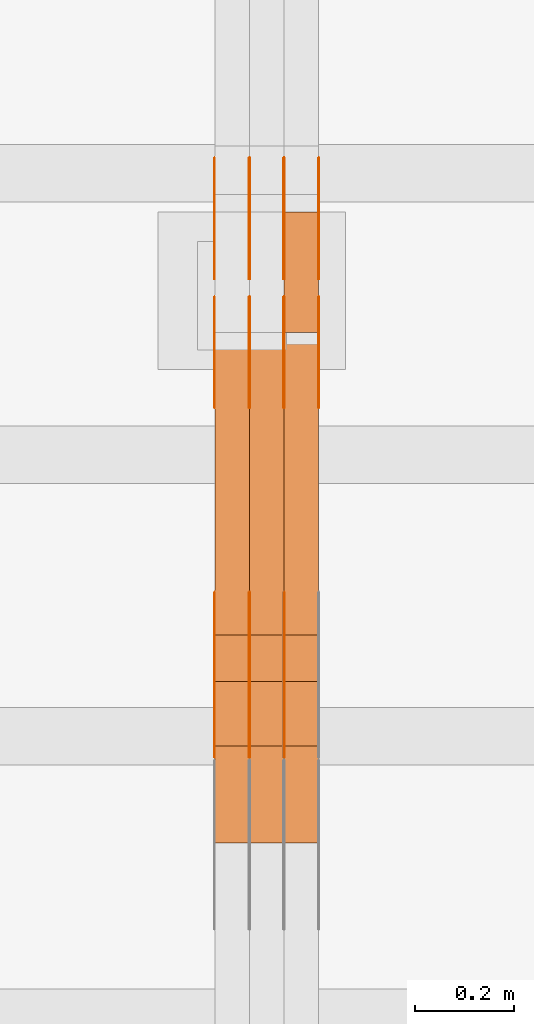
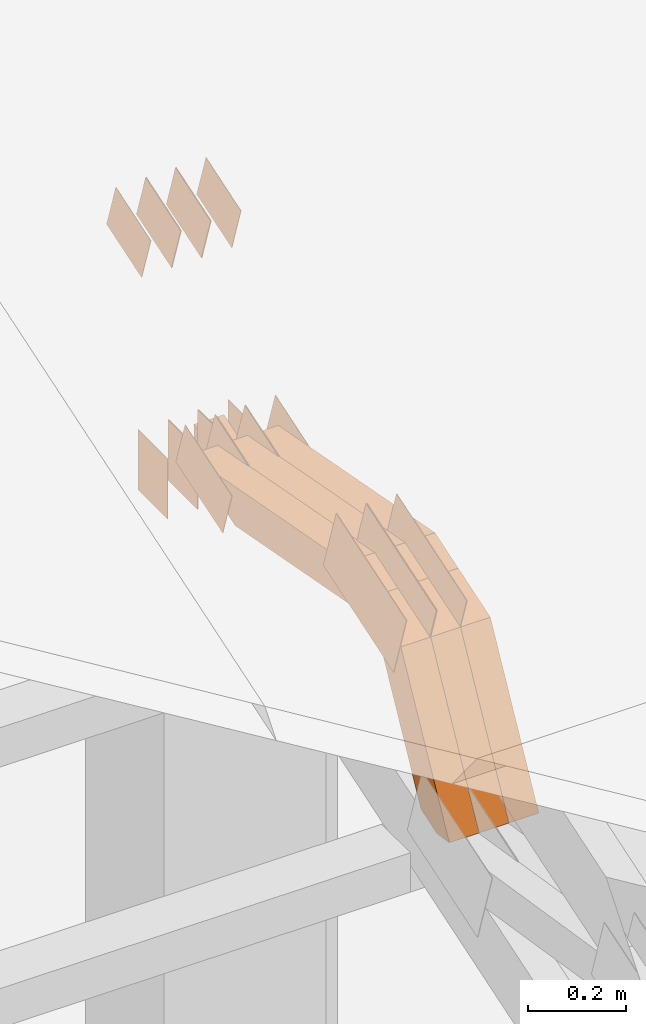
# One storey, part 142 of 385: 29 proxies.
"""IFC2X3 building model written with IfcOpenShell, lengths in millimetres."""

from ifc_helpers import new_model, entity, si_unit, converted_unit, derived_unit, direction, frame, frame_2d, origin, place, context, subcontext, project, spatial, polyline, rectangle, outline, extrude, source, transform, mapped, material, type_object, type_shapes, element, save


model = new_model("IFC2X3")

# Units and contexts
model_context = context("Model", 3, precision=0.01, world=origin(), true_north=direction((6.12303176911189e-17, 1.0)))
body_context = subcontext(model_context, "Body", "Model", "MODEL_VIEW")
ifc_project = project(units=[si_unit("LENGTHUNIT", "METRE", prefix="MILLI"), si_unit("AREAUNIT", "SQUARE_METRE"), si_unit("VOLUMEUNIT", "CUBIC_METRE"), converted_unit("PLANEANGLEUNIT", "DEGREE", entity("IfcRatioMeasure", 0.0174532925199433), si_unit("PLANEANGLEUNIT", "RADIAN"), dimensions=[0, 0, 0, 0, 0, 0, 0]), si_unit("MASSUNIT", "GRAM", prefix="KILO"), derived_unit("MASSDENSITYUNIT", [(si_unit("MASSUNIT", "GRAM", prefix="KILO"), 1), (si_unit("LENGTHUNIT", "METRE"), -3)]), si_unit("TIMEUNIT", "SECOND"), si_unit("FREQUENCYUNIT", "HERTZ"), si_unit("THERMODYNAMICTEMPERATUREUNIT", "DEGREE_CELSIUS"), derived_unit("THERMALTRANSMITTANCEUNIT", [(si_unit("MASSUNIT", "GRAM", prefix="KILO"), 1), (si_unit("THERMODYNAMICTEMPERATUREUNIT", "KELVIN"), -1), (si_unit("TIMEUNIT", "SECOND"), -3)]), derived_unit("VOLUMETRICFLOWRATEUNIT", [(si_unit("LENGTHUNIT", "METRE"), 3), (si_unit("TIMEUNIT", "SECOND"), -1)]), si_unit("ELECTRICCURRENTUNIT", "AMPERE"), si_unit("ELECTRICVOLTAGEUNIT", "VOLT"), si_unit("POWERUNIT", "WATT"), si_unit("FORCEUNIT", "NEWTON", prefix="KILO"), si_unit("ILLUMINANCEUNIT", "LUX"), si_unit("LUMINOUSFLUXUNIT", "LUMEN"), si_unit("LUMINOUSINTENSITYUNIT", "CANDELA"), derived_unit("USERDEFINED", [(si_unit("MASSUNIT", "GRAM", prefix="KILO"), -1), (si_unit("LENGTHUNIT", "METRE"), -2), (si_unit("TIMEUNIT", "SECOND"), 3), (si_unit("LUMINOUSFLUXUNIT", "LUMEN"), 1)]), derived_unit("LINEARVELOCITYUNIT", [(si_unit("LENGTHUNIT", "METRE"), 1), (si_unit("TIMEUNIT", "SECOND"), -1)]), si_unit("PRESSUREUNIT", "PASCAL"), derived_unit("USERDEFINED", [(si_unit("LENGTHUNIT", "METRE"), -2), (si_unit("MASSUNIT", "GRAM", prefix="KILO"), 1), (si_unit("TIMEUNIT", "SECOND"), -2)])], contexts=[model_context])

# Site, building, storey
site_placement = place(None, origin())
site = spatial("IfcSite", under=ifc_project, at=site_placement, CompositionType="ELEMENT")
building_placement = place(site_placement, origin())
building = spatial("IfcBuilding", under=site, at=building_placement, CompositionType="ELEMENT")
storey_placement = place(building_placement, origin())
storey = spatial("IfcBuildingStorey", under=building, at=storey_placement, Name="Default", CompositionType="ELEMENT", Elevation=0.0)

# Proxies
ifc_material_1 = material(Name="IfcSurfaceStyle #241520")
building_element_proxy_type_1 = type_object("IfcBuildingElementProxyType", PredefinedType="NOTDEFINED", material=ifc_material_1)
shared_shape_1 = source(origin(), body_context, "Body", "SweptSolid", [
    extrude(outline(polyline([(-99.9997874178038, -60.0000528641967), (99.9998102700997, -60.0000528641967), (99.9998251396068, 60.0000528641967), (-99.9998479919027, 60.0000528641967), (-99.9997874178038, -60.0000528641967)])), frame((99.9999918898597, 60.0000528641967, 0.0), z_axis=(0.0, 0.0, 1.0), x_axis=(-1.0, 0.0, 0.0)), (0.0, 0.0, 1.0), 1.3),
])
type_shapes(building_element_proxy_type_1, [shared_shape_1])
proxy_1_placement = place(building_placement, frame((18386.3, 11991.9568177725, 3072.52282247925), z_axis=(-1.0, 0.0, 0.0), x_axis=(0.0, 0.951056516295124, 0.309016994375039)))
element("IfcBuildingElementProxy", 1, at=proxy_1_placement, inside=storey, type_object=building_element_proxy_type_1, material=ifc_material_1, context=body_context, shape_type="MappedRepresentation", body=[
    mapped(shared_shape_1, transform((0.0, 0.0, 0.0), scale=1.0)),
])
ifc_material_2 = material(Name="IfcSurfaceStyle #241463")
building_element_proxy_type_2 = type_object("IfcBuildingElementProxyType", PredefinedType="NOTDEFINED", material=ifc_material_2)
shared_shape_2 = source(origin(), body_context, "Body", "SweptSolid", [
    extrude(outline(polyline([(-99.9997874178038, -60.0000528641967), (99.9998102700997, -60.0000528641967), (99.9998251396068, 60.0000528641967), (-99.9998479919027, 60.0000528641967), (-99.9997874178038, -60.0000528641967)])), frame((99.9999918898597, 60.0000528641967, 0.0), z_axis=(0.0, 0.0, 1.0), x_axis=(-1.0, 0.0, 0.0)), (0.0, 0.0, 1.0), 1.3),
])
type_shapes(building_element_proxy_type_2, [shared_shape_2])
proxy_2_placement = place(building_placement, frame((18315.0, 11991.9568177725, 3072.52282247925), z_axis=(-1.0, 0.0, 0.0), x_axis=(0.0, 0.951056516295124, 0.309016994375039)))
element("IfcBuildingElementProxy", 2, at=proxy_2_placement, inside=storey, type_object=building_element_proxy_type_2, material=ifc_material_2, context=body_context, shape_type="MappedRepresentation", body=[
    mapped(shared_shape_2, transform((0.0, 0.0, 0.0), scale=1.0)),
])
ifc_material_3 = material(Name="IfcSurfaceStyle #241406")
building_element_proxy_type_3 = type_object("IfcBuildingElementProxyType", PredefinedType="NOTDEFINED", material=ifc_material_3)
shared_shape_3 = source(origin(), body_context, "Body", "SweptSolid", [
    extrude(outline(polyline([(-99.9997874178038, -60.0000528641967), (99.9998102700997, -60.0000528641967), (99.9998251396068, 60.0000528641967), (-99.9998479919027, 60.0000528641967), (-99.9997874178038, -60.0000528641967)])), frame((99.9999918898597, 60.0000528641967, 0.0), z_axis=(0.0, 0.0, 1.0), x_axis=(-1.0, 0.0, 0.0)), (0.0, 0.0, 1.0), 1.3),
])
type_shapes(building_element_proxy_type_3, [shared_shape_3])
proxy_3_placement = place(building_placement, frame((18316.3, 11991.9568177725, 3072.52282247925), z_axis=(-1.0, 0.0, 0.0), x_axis=(0.0, 0.951056516295124, 0.309016994375039)))
element("IfcBuildingElementProxy", 3, at=proxy_3_placement, inside=storey, type_object=building_element_proxy_type_3, material=ifc_material_3, context=body_context, shape_type="MappedRepresentation", body=[
    mapped(shared_shape_3, transform((0.0, 0.0, 0.0), scale=1.0)),
])
ifc_material_4 = material(Name="IfcSurfaceStyle #241349")
building_element_proxy_type_4 = type_object("IfcBuildingElementProxyType", PredefinedType="NOTDEFINED", material=ifc_material_4)
shared_shape_4 = source(origin(), body_context, "Body", "SweptSolid", [
    extrude(outline(polyline([(-99.9997874178038, -60.0000528641967), (99.9998102700997, -60.0000528641967), (99.9998251396068, 60.0000528641967), (-99.9998479919027, 60.0000528641967), (-99.9997874178038, -60.0000528641967)])), frame((99.9999918898597, 60.0000528641967, 0.0), z_axis=(0.0, 0.0, 1.0), x_axis=(-1.0, 0.0, 0.0)), (0.0, 0.0, 1.0), 1.29999999999998),
])
type_shapes(building_element_proxy_type_4, [shared_shape_4])
proxy_4_placement = place(building_placement, frame((18245.0, 11991.9568177725, 3072.52282247925), z_axis=(-1.0, 0.0, 0.0), x_axis=(0.0, 0.951056516295124, 0.309016994375039)))
element("IfcBuildingElementProxy", 4, at=proxy_4_placement, inside=storey, type_object=building_element_proxy_type_4, material=ifc_material_4, context=body_context, shape_type="MappedRepresentation", body=[
    mapped(shared_shape_4, transform((0.0, 0.0, 0.0), scale=1.0)),
])
ifc_material_5 = material(Name="IfcSurfaceStyle #241292")
building_element_proxy_type_5 = type_object("IfcBuildingElementProxyType", PredefinedType="NOTDEFINED", material=ifc_material_5)
shared_shape_5 = source(origin(), body_context, "Body", "SweptSolid", [
    extrude(outline(polyline([(-99.9997874178038, -60.0000528641967), (99.9998102700997, -60.0000528641967), (99.9998251396068, 60.0000528641967), (-99.9998479919027, 60.0000528641967), (-99.9997874178038, -60.0000528641967)])), frame((99.9999918898597, 60.0000528641967, 0.0), z_axis=(0.0, 0.0, 1.0), x_axis=(-1.0, 0.0, 0.0)), (0.0, 0.0, 1.0), 1.29999999999998),
])
type_shapes(building_element_proxy_type_5, [shared_shape_5])
proxy_5_placement = place(building_placement, frame((18246.3, 11991.9568177725, 3072.52282247925), z_axis=(-1.0, 0.0, 0.0), x_axis=(0.0, 0.951056516295124, 0.309016994375039)))
element("IfcBuildingElementProxy", 5, at=proxy_5_placement, inside=storey, type_object=building_element_proxy_type_5, material=ifc_material_5, context=body_context, shape_type="MappedRepresentation", body=[
    mapped(shared_shape_5, transform((0.0, 0.0, 0.0), scale=1.0)),
])
ifc_material_6 = material(Name="IfcSurfaceStyle #241235")
building_element_proxy_type_6 = type_object("IfcBuildingElementProxyType", PredefinedType="NOTDEFINED", material=ifc_material_6)
shared_shape_6 = source(origin(), body_context, "Body", "SweptSolid", [
    extrude(outline(polyline([(-99.9997874178038, -60.0000528641967), (99.9998102700997, -60.0000528641967), (99.9998251396068, 60.0000528641967), (-99.9998479919027, 60.0000528641967), (-99.9997874178038, -60.0000528641967)])), frame((99.9999918898597, 60.0000528641967, 0.0), z_axis=(0.0, 0.0, 1.0), x_axis=(-1.0, 0.0, 0.0)), (0.0, 0.0, 1.0), 1.29999999999999),
])
type_shapes(building_element_proxy_type_6, [shared_shape_6])
proxy_6_placement = place(building_placement, frame((18175.0, 11991.9568177725, 3072.52282247925), z_axis=(-1.0, 0.0, 0.0), x_axis=(0.0, 0.951056516295124, 0.309016994375039)))
element("IfcBuildingElementProxy", 6, at=proxy_6_placement, inside=storey, type_object=building_element_proxy_type_6, material=ifc_material_6, context=body_context, shape_type="MappedRepresentation", body=[
    mapped(shared_shape_6, transform((0.0, 0.0, 0.0), scale=1.0)),
])
ifc_material_7 = material(Name="IfcSurfaceStyle #241178")
building_element_proxy_type_7 = type_object("IfcBuildingElementProxyType", PredefinedType="NOTDEFINED", material=ifc_material_7)
shared_shape_7 = source(origin(), body_context, "Body", "SweptSolid", [
    extrude(rectangle(XDim=150.0, YDim=119.999999999985, at=frame_2d((-7.105427357601e-15, 0.0), x_axis=(1.0, 0.0))), frame((75.0, 60.0, 0.0), z_axis=(0.0, 0.0, 1.0), x_axis=(-1.0, 0.0, 0.0)), (0.0, 0.0, 1.0), 1.3),
])
type_shapes(building_element_proxy_type_7, [shared_shape_7])
proxy_7_placement = place(building_placement, frame((18386.3, 12372.95703125, 3007.04687500001), z_axis=(-1.0, 0.0, 0.0), x_axis=(0.0, 0.0, -1.0)))
element("IfcBuildingElementProxy", 7, at=proxy_7_placement, inside=storey, type_object=building_element_proxy_type_7, material=ifc_material_7, context=body_context, shape_type="MappedRepresentation", body=[
    mapped(shared_shape_7, transform((0.0, 0.0, 0.0), scale=1.0)),
])
ifc_material_8 = material(Name="IfcSurfaceStyle #241121")
building_element_proxy_type_8 = type_object("IfcBuildingElementProxyType", PredefinedType="NOTDEFINED", material=ifc_material_8)
shared_shape_8 = source(origin(), body_context, "Body", "SweptSolid", [
    extrude(rectangle(XDim=150.0, YDim=119.999999999985, at=frame_2d((-7.105427357601e-15, 0.0), x_axis=(1.0, 0.0))), frame((75.0, 60.0, 0.0), z_axis=(0.0, 0.0, 1.0), x_axis=(-1.0, 0.0, 0.0)), (0.0, 0.0, 1.0), 1.3),
])
type_shapes(building_element_proxy_type_8, [shared_shape_8])
proxy_8_placement = place(building_placement, frame((18315.0, 12372.95703125, 3007.04687500001), z_axis=(-1.0, 0.0, 0.0), x_axis=(0.0, 0.0, -1.0)))
element("IfcBuildingElementProxy", 8, at=proxy_8_placement, inside=storey, type_object=building_element_proxy_type_8, material=ifc_material_8, context=body_context, shape_type="MappedRepresentation", body=[
    mapped(shared_shape_8, transform((0.0, 0.0, 0.0), scale=1.0)),
])
ifc_material_9 = material(Name="IfcSurfaceStyle #241064")
building_element_proxy_type_9 = type_object("IfcBuildingElementProxyType", PredefinedType="NOTDEFINED", material=ifc_material_9)
shared_shape_9 = source(origin(), body_context, "Body", "SweptSolid", [
    extrude(rectangle(XDim=150.0, YDim=119.999999999985, at=frame_2d((-7.105427357601e-15, 0.0), x_axis=(1.0, 0.0))), frame((75.0, 60.0, 0.0), z_axis=(0.0, 0.0, 1.0), x_axis=(-1.0, 0.0, 0.0)), (0.0, 0.0, 1.0), 1.3),
])
type_shapes(building_element_proxy_type_9, [shared_shape_9])
proxy_9_placement = place(building_placement, frame((18316.3, 12372.95703125, 3007.04687500001), z_axis=(-1.0, 0.0, 0.0), x_axis=(0.0, 0.0, -1.0)))
element("IfcBuildingElementProxy", 9, at=proxy_9_placement, inside=storey, type_object=building_element_proxy_type_9, material=ifc_material_9, context=body_context, shape_type="MappedRepresentation", body=[
    mapped(shared_shape_9, transform((0.0, 0.0, 0.0), scale=1.0)),
])
ifc_material_10 = material(Name="IfcSurfaceStyle #241007")
building_element_proxy_type_10 = type_object("IfcBuildingElementProxyType", PredefinedType="NOTDEFINED", material=ifc_material_10)
shared_shape_10 = source(origin(), body_context, "Body", "SweptSolid", [
    extrude(rectangle(XDim=150.0, YDim=119.999999999985, at=frame_2d((-7.105427357601e-15, 0.0), x_axis=(1.0, 0.0))), frame((75.0, 60.0, 0.0), z_axis=(0.0, 0.0, 1.0), x_axis=(-1.0, 0.0, 0.0)), (0.0, 0.0, 1.0), 1.29999999999999),
])
type_shapes(building_element_proxy_type_10, [shared_shape_10])
proxy_10_placement = place(building_placement, frame((18245.0, 12372.95703125, 3007.04687500001), z_axis=(-1.0, 0.0, 0.0), x_axis=(0.0, 0.0, -1.0)))
element("IfcBuildingElementProxy", 10, at=proxy_10_placement, inside=storey, type_object=building_element_proxy_type_10, material=ifc_material_10, context=body_context, shape_type="MappedRepresentation", body=[
    mapped(shared_shape_10, transform((0.0, 0.0, 0.0), scale=1.0)),
])
ifc_material_11 = material(Name="IfcSurfaceStyle #240950")
building_element_proxy_type_11 = type_object("IfcBuildingElementProxyType", PredefinedType="NOTDEFINED", material=ifc_material_11)
shared_shape_11 = source(origin(), body_context, "Body", "SweptSolid", [
    extrude(rectangle(XDim=150.0, YDim=119.999999999985, at=frame_2d((-7.105427357601e-15, 0.0), x_axis=(1.0, 0.0))), frame((75.0, 60.0, 0.0), z_axis=(0.0, 0.0, 1.0), x_axis=(-1.0, 0.0, 0.0)), (0.0, 0.0, 1.0), 1.29999999999999),
])
type_shapes(building_element_proxy_type_11, [shared_shape_11])
proxy_11_placement = place(building_placement, frame((18246.3, 12372.95703125, 3007.04687500001), z_axis=(-1.0, 0.0, 0.0), x_axis=(0.0, 0.0, -1.0)))
element("IfcBuildingElementProxy", 11, at=proxy_11_placement, inside=storey, type_object=building_element_proxy_type_11, material=ifc_material_11, context=body_context, shape_type="MappedRepresentation", body=[
    mapped(shared_shape_11, transform((0.0, 0.0, 0.0), scale=1.0)),
])
ifc_material_12 = material(Name="IfcSurfaceStyle #240893")
building_element_proxy_type_12 = type_object("IfcBuildingElementProxyType", PredefinedType="NOTDEFINED", material=ifc_material_12)
shared_shape_12 = source(origin(), body_context, "Body", "SweptSolid", [
    extrude(rectangle(XDim=150.0, YDim=119.999999999985, at=frame_2d((-7.105427357601e-15, 0.0), x_axis=(1.0, 0.0))), frame((75.0, 60.0, 0.0), z_axis=(0.0, 0.0, 1.0), x_axis=(-1.0, 0.0, 0.0)), (0.0, 0.0, 1.0), 1.29999999999999),
])
type_shapes(building_element_proxy_type_12, [shared_shape_12])
proxy_12_placement = place(building_placement, frame((18175.0, 12372.95703125, 3007.04687500001), z_axis=(-1.0, 0.0, 0.0), x_axis=(0.0, 0.0, -1.0)))
element("IfcBuildingElementProxy", 12, at=proxy_12_placement, inside=storey, type_object=building_element_proxy_type_12, material=ifc_material_12, context=body_context, shape_type="MappedRepresentation", body=[
    mapped(shared_shape_12, transform((0.0, 0.0, 0.0), scale=1.0)),
])
ifc_material_13 = material(Name="IfcSurfaceStyle #233996")
building_element_proxy_type_13 = type_object("IfcBuildingElementProxyType", PredefinedType="NOTDEFINED", material=ifc_material_13)
shared_shape_13 = source(origin(), body_context, "Body", "SweptSolid", [
    extrude(outline(polyline([(-74.9998754286244, -60.0000016373506), (74.9998605591063, -60.0000016373506), (74.9998754286244, 60.0000016373506), (-74.9998605591063, 60.0000016373506), (-74.9998754286244, -60.0000016373506)])), frame((74.9998754286244, 60.0000016373506, 0.0), z_axis=(0.0, 0.0, 1.0), x_axis=(-1.0, 0.0, 0.0)), (0.0, 0.0, 1.0), 1.3),
])
type_shapes(building_element_proxy_type_13, [shared_shape_13])
proxy_13_placement = place(building_placement, frame((18386.3, 12321.1620861463, 3506.17707344366), z_axis=(-1.0, 0.0, 0.0), x_axis=(0.0, 0.951056516295154, 0.309016994374948)))
element("IfcBuildingElementProxy", 13, at=proxy_13_placement, inside=storey, type_object=building_element_proxy_type_13, material=ifc_material_13, context=body_context, shape_type="MappedRepresentation", body=[
    mapped(shared_shape_13, transform((0.0, 0.0, 0.0), scale=1.0)),
])
ifc_material_14 = material(Name="IfcSurfaceStyle #233939")
building_element_proxy_type_14 = type_object("IfcBuildingElementProxyType", PredefinedType="NOTDEFINED", material=ifc_material_14)
shared_shape_14 = source(origin(), body_context, "Body", "SweptSolid", [
    extrude(outline(polyline([(-74.9998754286244, -60.0000016373506), (74.9998605591063, -60.0000016373506), (74.9998754286244, 60.0000016373506), (-74.9998605591063, 60.0000016373506), (-74.9998754286244, -60.0000016373506)])), frame((74.9998754286244, 60.0000016373506, 0.0), z_axis=(0.0, 0.0, 1.0), x_axis=(-1.0, 0.0, 0.0)), (0.0, 0.0, 1.0), 1.3),
])
type_shapes(building_element_proxy_type_14, [shared_shape_14])
proxy_14_placement = place(building_placement, frame((18315.0, 12321.1620861463, 3506.17707344366), z_axis=(-1.0, 0.0, 0.0), x_axis=(0.0, 0.951056516295154, 0.309016994374948)))
element("IfcBuildingElementProxy", 14, at=proxy_14_placement, inside=storey, type_object=building_element_proxy_type_14, material=ifc_material_14, context=body_context, shape_type="MappedRepresentation", body=[
    mapped(shared_shape_14, transform((0.0, 0.0, 0.0), scale=1.0)),
])
ifc_material_15 = material(Name="IfcSurfaceStyle #233882")
building_element_proxy_type_15 = type_object("IfcBuildingElementProxyType", PredefinedType="NOTDEFINED", material=ifc_material_15)
shared_shape_15 = source(origin(), body_context, "Body", "SweptSolid", [
    extrude(outline(polyline([(-74.9998754286244, -60.0000016373506), (74.9998605591063, -60.0000016373506), (74.9998754286244, 60.0000016373506), (-74.9998605591063, 60.0000016373506), (-74.9998754286244, -60.0000016373506)])), frame((74.9998754286244, 60.0000016373506, 0.0), z_axis=(0.0, 0.0, 1.0), x_axis=(-1.0, 0.0, 0.0)), (0.0, 0.0, 1.0), 1.3),
])
type_shapes(building_element_proxy_type_15, [shared_shape_15])
proxy_15_placement = place(building_placement, frame((18316.3, 12321.1620861463, 3506.17707344366), z_axis=(-1.0, 0.0, 0.0), x_axis=(0.0, 0.951056516295154, 0.309016994374948)))
element("IfcBuildingElementProxy", 15, at=proxy_15_placement, inside=storey, type_object=building_element_proxy_type_15, material=ifc_material_15, context=body_context, shape_type="MappedRepresentation", body=[
    mapped(shared_shape_15, transform((0.0, 0.0, 0.0), scale=1.0)),
])
ifc_material_16 = material(Name="IfcSurfaceStyle #233825")
building_element_proxy_type_16 = type_object("IfcBuildingElementProxyType", PredefinedType="NOTDEFINED", material=ifc_material_16)
shared_shape_16 = source(origin(), body_context, "Body", "SweptSolid", [
    extrude(outline(polyline([(-74.9998754286244, -60.0000016373506), (74.9998605591063, -60.0000016373506), (74.9998754286244, 60.0000016373506), (-74.9998605591063, 60.0000016373506), (-74.9998754286244, -60.0000016373506)])), frame((74.9998754286244, 60.0000016373506, 0.0), z_axis=(0.0, 0.0, 1.0), x_axis=(-1.0, 0.0, 0.0)), (0.0, 0.0, 1.0), 1.29999999999999),
])
type_shapes(building_element_proxy_type_16, [shared_shape_16])
proxy_16_placement = place(building_placement, frame((18245.0, 12321.1620861463, 3506.17707344366), z_axis=(-1.0, 0.0, 0.0), x_axis=(0.0, 0.951056516295154, 0.309016994374948)))
element("IfcBuildingElementProxy", 16, at=proxy_16_placement, inside=storey, type_object=building_element_proxy_type_16, material=ifc_material_16, context=body_context, shape_type="MappedRepresentation", body=[
    mapped(shared_shape_16, transform((0.0, 0.0, 0.0), scale=1.0)),
])
ifc_material_17 = material(Name="IfcSurfaceStyle #233768")
building_element_proxy_type_17 = type_object("IfcBuildingElementProxyType", PredefinedType="NOTDEFINED", material=ifc_material_17)
shared_shape_17 = source(origin(), body_context, "Body", "SweptSolid", [
    extrude(outline(polyline([(-74.9998754286244, -60.0000016373506), (74.9998605591063, -60.0000016373506), (74.9998754286244, 60.0000016373506), (-74.9998605591063, 60.0000016373506), (-74.9998754286244, -60.0000016373506)])), frame((74.9998754286244, 60.0000016373506, 0.0), z_axis=(0.0, 0.0, 1.0), x_axis=(-1.0, 0.0, 0.0)), (0.0, 0.0, 1.0), 1.29999999999999),
])
type_shapes(building_element_proxy_type_17, [shared_shape_17])
proxy_17_placement = place(building_placement, frame((18246.3, 12321.1620861463, 3506.17707344366), z_axis=(-1.0, 0.0, 0.0), x_axis=(0.0, 0.951056516295154, 0.309016994374948)))
element("IfcBuildingElementProxy", 17, at=proxy_17_placement, inside=storey, type_object=building_element_proxy_type_17, material=ifc_material_17, context=body_context, shape_type="MappedRepresentation", body=[
    mapped(shared_shape_17, transform((0.0, 0.0, 0.0), scale=1.0)),
])
ifc_material_18 = material(Name="IfcSurfaceStyle #233711")
building_element_proxy_type_18 = type_object("IfcBuildingElementProxyType", PredefinedType="NOTDEFINED", material=ifc_material_18)
shared_shape_18 = source(origin(), body_context, "Body", "SweptSolid", [
    extrude(outline(polyline([(-74.9998754286244, -60.0000016373506), (74.9998605591063, -60.0000016373506), (74.9998754286244, 60.0000016373506), (-74.9998605591063, 60.0000016373506), (-74.9998754286244, -60.0000016373506)])), frame((74.9998754286244, 60.0000016373506, 0.0), z_axis=(0.0, 0.0, 1.0), x_axis=(-1.0, 0.0, 0.0)), (0.0, 0.0, 1.0), 1.29999999999999),
])
type_shapes(building_element_proxy_type_18, [shared_shape_18])
proxy_18_placement = place(building_placement, frame((18175.0, 12321.1620861463, 3506.17707344366), z_axis=(-1.0, 0.0, 0.0), x_axis=(0.0, 0.951056516295154, 0.309016994374948)))
element("IfcBuildingElementProxy", 18, at=proxy_18_placement, inside=storey, type_object=building_element_proxy_type_18, material=ifc_material_18, context=body_context, shape_type="MappedRepresentation", body=[
    mapped(shared_shape_18, transform((0.0, 0.0, 0.0), scale=1.0)),
])
ifc_material_19 = material(Name="IfcSurfaceStyle #233198")
building_element_proxy_type_19 = type_object("IfcBuildingElementProxyType", PredefinedType="NOTDEFINED", material=ifc_material_19)
shared_shape_19 = source(origin(), body_context, "Body", "SweptSolid", [
    extrude(outline(polyline([(-150.000273478628, -84.0002987844282), (149.999198496832, -84.0002987844282), (150.000273478627, 84.0002987844282), (-149.999198496831, 84.0002987844282), (-150.000273478628, -84.0002987844282)])), frame((150.000273478627, 84.0002987844282, 0.0), z_axis=(0.0, 0.0, 1.0), x_axis=(-1.0, 0.0, 0.0)), (0.0, 0.0, 1.0), 1.29999999999999),
])
type_shapes(building_element_proxy_type_19, [shared_shape_19])
proxy_19_placement = place(building_placement, frame((18316.3, 11283.0116722926, 3194.09682266857), z_axis=(-1.0, 0.0, 0.0), x_axis=(0.0, 0.951056516295154, 0.309016994374948)))
element("IfcBuildingElementProxy", 19, at=proxy_19_placement, inside=storey, type_object=building_element_proxy_type_19, material=ifc_material_19, context=body_context, shape_type="MappedRepresentation", body=[
    mapped(shared_shape_19, transform((0.0, 0.0, 0.0), scale=1.0)),
])
ifc_material_20 = material(Name="IfcSurfaceStyle #233141")
building_element_proxy_type_20 = type_object("IfcBuildingElementProxyType", PredefinedType="NOTDEFINED", material=ifc_material_20)
shared_shape_20 = source(origin(), body_context, "Body", "SweptSolid", [
    extrude(outline(polyline([(-150.000273478628, -84.0002987844282), (149.999198496832, -84.0002987844282), (150.000273478627, 84.0002987844282), (-149.999198496831, 84.0002987844282), (-150.000273478628, -84.0002987844282)])), frame((150.000273478627, 84.0002987844282, 0.0), z_axis=(0.0, 0.0, 1.0), x_axis=(-1.0, 0.0, 0.0)), (0.0, 0.0, 1.0), 1.29999999999998),
])
type_shapes(building_element_proxy_type_20, [shared_shape_20])
proxy_20_placement = place(building_placement, frame((18245.0, 11283.0116722926, 3194.09682266857), z_axis=(-1.0, 0.0, 0.0), x_axis=(0.0, 0.951056516295154, 0.309016994374948)))
element("IfcBuildingElementProxy", 20, at=proxy_20_placement, inside=storey, type_object=building_element_proxy_type_20, material=ifc_material_20, context=body_context, shape_type="MappedRepresentation", body=[
    mapped(shared_shape_20, transform((0.0, 0.0, 0.0), scale=1.0)),
])
ifc_material_21 = material(Name="IfcSurfaceStyle #233084")
building_element_proxy_type_21 = type_object("IfcBuildingElementProxyType", PredefinedType="NOTDEFINED", material=ifc_material_21)
shared_shape_21 = source(origin(), body_context, "Body", "SweptSolid", [
    extrude(outline(polyline([(-150.000273478628, -84.0002987844282), (149.999198496832, -84.0002987844282), (150.000273478627, 84.0002987844282), (-149.999198496831, 84.0002987844282), (-150.000273478628, -84.0002987844282)])), frame((150.000273478627, 84.0002987844282, 0.0), z_axis=(0.0, 0.0, 1.0), x_axis=(-1.0, 0.0, 0.0)), (0.0, 0.0, 1.0), 1.29999999999998),
])
type_shapes(building_element_proxy_type_21, [shared_shape_21])
proxy_21_placement = place(building_placement, frame((18246.3, 11283.0116722926, 3194.09682266857), z_axis=(-1.0, 0.0, 0.0), x_axis=(0.0, 0.951056516295154, 0.309016994374948)))
element("IfcBuildingElementProxy", 21, at=proxy_21_placement, inside=storey, type_object=building_element_proxy_type_21, material=ifc_material_21, context=body_context, shape_type="MappedRepresentation", body=[
    mapped(shared_shape_21, transform((0.0, 0.0, 0.0), scale=1.0)),
])
ifc_material_22 = material(Name="IfcSurfaceStyle #233027")
building_element_proxy_type_22 = type_object("IfcBuildingElementProxyType", PredefinedType="NOTDEFINED", material=ifc_material_22)
shared_shape_22 = source(origin(), body_context, "Body", "SweptSolid", [
    extrude(outline(polyline([(-150.000273478628, -84.0002987844282), (149.999198496832, -84.0002987844282), (150.000273478627, 84.0002987844282), (-149.999198496831, 84.0002987844282), (-150.000273478628, -84.0002987844282)])), frame((150.000273478627, 84.0002987844282, 0.0), z_axis=(0.0, 0.0, 1.0), x_axis=(-1.0, 0.0, 0.0)), (0.0, 0.0, 1.0), 1.29999999999998),
])
type_shapes(building_element_proxy_type_22, [shared_shape_22])
proxy_22_placement = place(building_placement, frame((18175.0, 11283.0116722926, 3194.09682266857), z_axis=(-1.0, 0.0, 0.0), x_axis=(0.0, 0.951056516295154, 0.309016994374948)))
element("IfcBuildingElementProxy", 22, at=proxy_22_placement, inside=storey, type_object=building_element_proxy_type_22, material=ifc_material_22, context=body_context, shape_type="MappedRepresentation", body=[
    mapped(shared_shape_22, transform((0.0, 0.0, 0.0), scale=1.0)),
])
ifc_material_23 = material(Name="IfcSurfaceStyle #225536")
building_element_proxy_type_23 = type_object("IfcBuildingElementProxyType", Name="T1-E1 225534", PredefinedType="NOTDEFINED", material=ifc_material_23)
shared_shape_23 = source(origin(), body_context, "Body", "SweptSolid", [
    extrude(outline(polyline([(-75.1378173828004, -122.500000000005), (35.3350830078246, -122.500000000005), (35.3350830078004, 122.500000000005), (4.46765136717545, 122.500000000005), (-75.1378173828004, -122.500000000005)])), frame((35.3350830078246, 122.500000104877, 0.0), z_axis=(0.0, 0.0, 1.0), x_axis=(-1.0, 0.0, 0.0)), (0.0, 0.0, 1.0), 70.0),
])
type_shapes(building_element_proxy_type_23, [shared_shape_23])
proxy_23_placement = place(building_placement, frame((18385.0, 12145.0, 2849.54565429685), z_axis=(-1.0, 0.0, 0.0), x_axis=(0.0, 0.0, 1.0)))
element("IfcBuildingElementProxy", 23, at=proxy_23_placement, inside=storey, type_object=building_element_proxy_type_23, material=ifc_material_23, Name="T1-E1", context=body_context, shape_type="MappedRepresentation", body=[
    mapped(shared_shape_23, transform((0.0, 0.0, 0.0), scale=1.0)),
])
ifc_material_24 = material(Name="IfcSurfaceStyle #223016")
building_element_proxy_type_24 = type_object("IfcBuildingElementProxyType", Name="T1-W9 223014", PredefinedType="NOTDEFINED", material=ifc_material_24)
shared_shape_24 = source(origin(), body_context, "Body", "SweptSolid", [
    extrude(outline(polyline([(-287.457507623288, -47.5000268597988), (288.590479960635, -47.5000268597988), (273.55062971372, -2.33146189358546e-05), (186.625054999886, 47.5000385171083), (-461.308657050953, 47.5000385171083), (-287.457507623288, -47.5000268597988)])), frame((288.590945855618, 47.5000968036551, 0.0), z_axis=(0.0, 0.0, 1.0), x_axis=(-1.0, 0.0, 0.0)), (0.0, 0.0, 1.0), 70.0),
])
type_shapes(building_element_proxy_type_24, [shared_shape_24])
proxy_24_placement = place(building_placement, frame((18385.0, 11432.1200855376, 3205.63308612017), z_axis=(-1.0, 0.0, 0.0), x_axis=(0.0, 0.982760503514031, -0.184883186722992)))
element("IfcBuildingElementProxy", 24, at=proxy_24_placement, inside=storey, type_object=building_element_proxy_type_24, material=ifc_material_24, Name="T1-W9", context=body_context, shape_type="MappedRepresentation", body=[
    mapped(shared_shape_24, transform((0.0, 0.0, 0.0), scale=1.0)),
])
ifc_material_25 = material(Name="IfcSurfaceStyle #222950")
building_element_proxy_type_25 = type_object("IfcBuildingElementProxyType", Name="T1-W9 222948", PredefinedType="NOTDEFINED", material=ifc_material_25)
shared_shape_25 = source(origin(), body_context, "Body", "SweptSolid", [
    extrude(outline(polyline([(-287.457507623288, -47.5000268597988), (288.590479960635, -47.5000268597988), (273.55062971372, -2.33146189358546e-05), (186.625054999886, 47.5000385171083), (-461.308657050953, 47.5000385171083), (-287.457507623288, -47.5000268597988)])), frame((288.590945855618, 47.5000968036551, 0.0), z_axis=(0.0, 0.0, 1.0), x_axis=(-1.0, 0.0, 0.0)), (0.0, 0.0, 1.0), 70.0),
])
type_shapes(building_element_proxy_type_25, [shared_shape_25])
proxy_25_placement = place(building_placement, frame((18315.0, 11432.1200855376, 3205.63308612017), z_axis=(-1.0, 0.0, 0.0), x_axis=(0.0, 0.982760503514031, -0.184883186722992)))
element("IfcBuildingElementProxy", 25, at=proxy_25_placement, inside=storey, type_object=building_element_proxy_type_25, material=ifc_material_25, Name="T1-W9", context=body_context, shape_type="MappedRepresentation", body=[
    mapped(shared_shape_25, transform((0.0, 0.0, 0.0), scale=1.0)),
])
ifc_material_26 = material(Name="IfcSurfaceStyle #222884")
building_element_proxy_type_26 = type_object("IfcBuildingElementProxyType", Name="T1-W9 222882", PredefinedType="NOTDEFINED", material=ifc_material_26)
shared_shape_26 = source(origin(), body_context, "Body", "SweptSolid", [
    extrude(outline(polyline([(-287.457507623288, -47.5000268597988), (288.590479960635, -47.5000268597988), (273.55062971372, -2.33146189358546e-05), (186.625054999886, 47.5000385171083), (-461.308657050953, 47.5000385171083), (-287.457507623288, -47.5000268597988)])), frame((288.590945855618, 47.5000968036551, 0.0), z_axis=(0.0, 0.0, 1.0), x_axis=(-1.0, 0.0, 0.0)), (0.0, 0.0, 1.0), 70.0),
])
type_shapes(building_element_proxy_type_26, [shared_shape_26])
proxy_26_placement = place(building_placement, frame((18245.0, 11432.1200855376, 3205.63308612017), z_axis=(-1.0, 0.0, 0.0), x_axis=(0.0, 0.982760503514031, -0.184883186722992)))
element("IfcBuildingElementProxy", 26, at=proxy_26_placement, inside=storey, type_object=building_element_proxy_type_26, material=ifc_material_26, Name="T1-W9", context=body_context, shape_type="MappedRepresentation", body=[
    mapped(shared_shape_26, transform((0.0, 0.0, 0.0), scale=1.0)),
])
ifc_material_27 = material(Name="IfcSurfaceStyle #222620")
building_element_proxy_type_27 = type_object("IfcBuildingElementProxyType", Name="T1-W32 222618", PredefinedType="NOTDEFINED", material=ifc_material_27)
shared_shape_27 = source(origin(), body_context, "Body", "SweptSolid", [
    extrude(outline(polyline([(-312.414547135921, -47.5000544873059), (136.677011757652, -47.5000544873059), (186.250996577889, 0.000369497452627243), (202.753116295831, 47.4998697385796), (-213.26657749545, 47.4998697385796), (-312.414547135921, -47.5000544873059)])), frame((202.753376481939, 47.5001296985553, 0.0), z_axis=(0.0, 0.0, 1.0), x_axis=(-1.0, 0.0, 0.0)), (0.0, 0.0, 1.0), 70.0),
])
type_shapes(building_element_proxy_type_27, [shared_shape_27])
proxy_27_placement = place(building_placement, frame((18385.0, 11110.7808979007, 2747.18129017315), z_axis=(-1.0, 0.0, 0.0), x_axis=(0.0, 0.472919689385906, 0.881105537033526)))
element("IfcBuildingElementProxy", 27, at=proxy_27_placement, inside=storey, type_object=building_element_proxy_type_27, material=ifc_material_27, Name="T1-W32", context=body_context, shape_type="MappedRepresentation", body=[
    mapped(shared_shape_27, transform((0.0, 0.0, 0.0), scale=1.0)),
])
ifc_material_28 = material(Name="IfcSurfaceStyle #222554")
building_element_proxy_type_28 = type_object("IfcBuildingElementProxyType", Name="T1-W32 222552", PredefinedType="NOTDEFINED", material=ifc_material_28)
shared_shape_28 = source(origin(), body_context, "Body", "SweptSolid", [
    extrude(outline(polyline([(-312.414547135921, -47.5000544873059), (136.677011757652, -47.5000544873059), (186.250996577889, 0.000369497452627243), (202.753116295831, 47.4998697385796), (-213.26657749545, 47.4998697385796), (-312.414547135921, -47.5000544873059)])), frame((202.753376481939, 47.5001296985553, 0.0), z_axis=(0.0, 0.0, 1.0), x_axis=(-1.0, 0.0, 0.0)), (0.0, 0.0, 1.0), 70.0),
])
type_shapes(building_element_proxy_type_28, [shared_shape_28])
proxy_28_placement = place(building_placement, frame((18315.0, 11110.7808979007, 2747.18129017315), z_axis=(-1.0, 0.0, 0.0), x_axis=(0.0, 0.472919689385906, 0.881105537033526)))
element("IfcBuildingElementProxy", 28, at=proxy_28_placement, inside=storey, type_object=building_element_proxy_type_28, material=ifc_material_28, Name="T1-W32", context=body_context, shape_type="MappedRepresentation", body=[
    mapped(shared_shape_28, transform((0.0, 0.0, 0.0), scale=1.0)),
])
ifc_material_29 = material(Name="IfcSurfaceStyle #222488")
building_element_proxy_type_29 = type_object("IfcBuildingElementProxyType", Name="T1-W32 222486", PredefinedType="NOTDEFINED", material=ifc_material_29)
shared_shape_29 = source(origin(), body_context, "Body", "SweptSolid", [
    extrude(outline(polyline([(-312.414547135921, -47.5000544873059), (136.677011757652, -47.5000544873059), (186.250996577889, 0.000369497452627243), (202.753116295831, 47.4998697385796), (-213.26657749545, 47.4998697385796), (-312.414547135921, -47.5000544873059)])), frame((202.753376481939, 47.5001296985553, 0.0), z_axis=(0.0, 0.0, 1.0), x_axis=(-1.0, 0.0, 0.0)), (0.0, 0.0, 1.0), 70.0),
])
type_shapes(building_element_proxy_type_29, [shared_shape_29])
proxy_29_placement = place(building_placement, frame((18245.0, 11110.7808979007, 2747.18129017315), z_axis=(-1.0, 0.0, 0.0), x_axis=(0.0, 0.472919689385906, 0.881105537033526)))
element("IfcBuildingElementProxy", 29, at=proxy_29_placement, inside=storey, type_object=building_element_proxy_type_29, material=ifc_material_29, Name="T1-W32", context=body_context, shape_type="MappedRepresentation", body=[
    mapped(shared_shape_29, transform((0.0, 0.0, 0.0), scale=1.0)),
])

save(model, "model.ifc")
